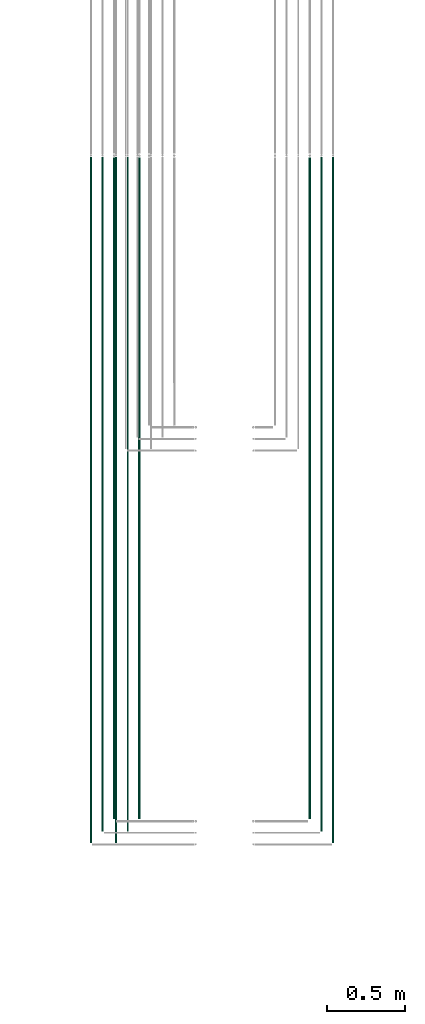
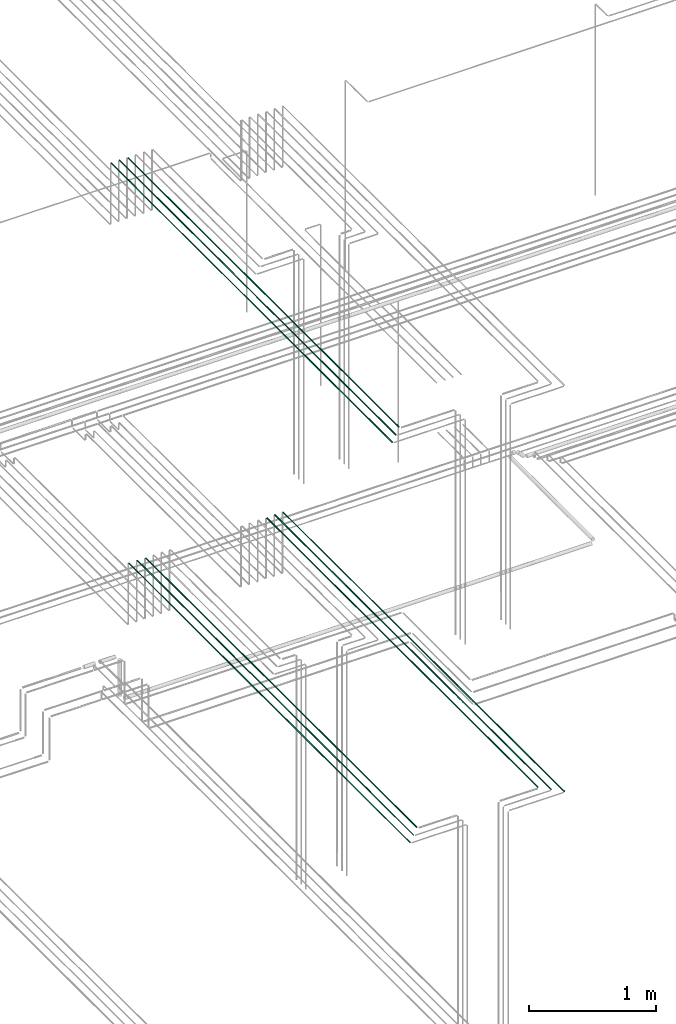
# One storey, part 10 of 331: 9 flow segments.
"""IFC2X3 building model written with IfcOpenShell, lengths in millimetres."""

from ifc_helpers import new_model, entity, si_unit, converted_unit, derived_unit, direction, frame, frame_2d, origin, origin_2d_with_axis, place, context, subcontext, project, spatial, circle, extrude, type_object, element, save


model = new_model("IFC2X3")

# Units and contexts
model_context = context("Model", 3, precision=0.01, world=origin(), true_north=direction((6.12303176911189e-17, 1.0)))
body_context = subcontext(model_context, "Body", "Model", "MODEL_VIEW")
ifc_project = project(units=[si_unit("LENGTHUNIT", "METRE", prefix="MILLI"), si_unit("AREAUNIT", "SQUARE_METRE"), si_unit("VOLUMEUNIT", "CUBIC_METRE"), converted_unit("PLANEANGLEUNIT", "DEGREE", entity("IfcRatioMeasure", 0.0174532925199433), si_unit("PLANEANGLEUNIT", "RADIAN"), dimensions=[0, 0, 0, 0, 0, 0, 0]), si_unit("MASSUNIT", "GRAM", prefix="KILO"), derived_unit("MASSDENSITYUNIT", [(si_unit("MASSUNIT", "GRAM", prefix="KILO"), 1), (si_unit("LENGTHUNIT", "METRE"), -3)]), derived_unit("MOMENTOFINERTIAUNIT", [(si_unit("LENGTHUNIT", "METRE"), 4)]), si_unit("TIMEUNIT", "SECOND"), si_unit("FREQUENCYUNIT", "HERTZ"), si_unit("THERMODYNAMICTEMPERATUREUNIT", "DEGREE_CELSIUS"), derived_unit("THERMALTRANSMITTANCEUNIT", [(si_unit("MASSUNIT", "GRAM", prefix="KILO"), 1), (si_unit("THERMODYNAMICTEMPERATUREUNIT", "KELVIN"), -1), (si_unit("TIMEUNIT", "SECOND"), -3)]), derived_unit("VOLUMETRICFLOWRATEUNIT", [(si_unit("LENGTHUNIT", "METRE"), 3), (si_unit("TIMEUNIT", "SECOND"), -1)]), derived_unit("MASSFLOWRATEUNIT", [(si_unit("MASSUNIT", "GRAM", prefix="KILO"), 1), (si_unit("TIMEUNIT", "SECOND"), -1)]), derived_unit("ROTATIONALFREQUENCYUNIT", [(si_unit("TIMEUNIT", "SECOND"), -1)]), si_unit("ELECTRICCURRENTUNIT", "AMPERE"), si_unit("ELECTRICVOLTAGEUNIT", "VOLT"), si_unit("POWERUNIT", "WATT"), si_unit("FORCEUNIT", "NEWTON", prefix="KILO"), si_unit("ILLUMINANCEUNIT", "LUX"), si_unit("LUMINOUSFLUXUNIT", "LUMEN"), si_unit("LUMINOUSINTENSITYUNIT", "CANDELA"), derived_unit("USERDEFINED", [(si_unit("MASSUNIT", "GRAM", prefix="KILO"), -1), (si_unit("LENGTHUNIT", "METRE"), -2), (si_unit("TIMEUNIT", "SECOND"), 3), (si_unit("LUMINOUSFLUXUNIT", "LUMEN"), 1)]), derived_unit("LINEARVELOCITYUNIT", [(si_unit("LENGTHUNIT", "METRE"), 1), (si_unit("TIMEUNIT", "SECOND"), -1)]), si_unit("PRESSUREUNIT", "PASCAL"), derived_unit("USERDEFINED", [(si_unit("LENGTHUNIT", "METRE"), -2), (si_unit("MASSUNIT", "GRAM", prefix="KILO"), 1), (si_unit("TIMEUNIT", "SECOND"), -2)]), derived_unit("LINEARFORCEUNIT", [(si_unit("MASSUNIT", "GRAM", prefix="KILO"), 1), (si_unit("LENGTHUNIT", "METRE"), 1), (si_unit("TIMEUNIT", "SECOND"), -2), (si_unit("LENGTHUNIT", "METRE"), -1)]), derived_unit("PLANARFORCEUNIT", [(si_unit("MASSUNIT", "GRAM", prefix="KILO"), 1), (si_unit("LENGTHUNIT", "METRE"), 1), (si_unit("TIMEUNIT", "SECOND"), -2), (si_unit("LENGTHUNIT", "METRE"), -2)])], contexts=[model_context])

# Site, building, storey
site_placement = place(None, frame((0.0, -0.00077364408347762, 0.0)))
site = spatial("IfcSite", under=ifc_project, at=site_placement, CompositionType="ELEMENT")
building_placement = place(site_placement, origin())
building = spatial("IfcBuilding", under=site, at=building_placement, CompositionType="ELEMENT")
storey_placement = place(building_placement, origin())
storey = spatial("IfcBuildingStorey", under=building, at=storey_placement, CompositionType="ELEMENT", Elevation=0.0)

# Flow segments
pipe_segment_type = type_object("IfcPipeSegmentType", PredefinedType="NOTDEFINED")
flow_segment_1_placement = place(storey_placement, frame((26313.5132663482, 1365.48876707896, 15142.4047277641)))
element("IfcFlowSegment", 1, at=flow_segment_1_placement, inside=storey, type_object=pipe_segment_type, context=body_context, shape_type="SweptSolid", body=[
    extrude(circle(Radius=6.0, at=frame_2d((0.0, 2.16573425859679e-12), x_axis=(1.0, 0.0))), frame((7.59527223591454, 0.0, 7.59527223591887), z_axis=(0.0, 1.0, 0.0), x_axis=(1.0, 0.0, 0.0)), (0.0, 0.0, 1.0), 4264.13179674845),
])
flow_segment_2_placement = place(storey_placement, frame((26390.5132663482, 1286.48876707975, 15144.4047277641)))
element("IfcFlowSegment", 2, at=flow_segment_2_placement, inside=storey, type_object=pipe_segment_type, context=body_context, shape_type="SweptSolid", body=[
    extrude(circle(Radius=4.0, at=origin_2d_with_axis()), frame((5.59527223591499, 0.0, 5.59527223591499), z_axis=(0.0, 1.0, 0.0), x_axis=(1.0, 0.0, 0.0)), (0.0, 0.0, 1.0), 4347.13179674766),
])
flow_segment_3_placement = place(storey_placement, frame((26465.5132663482, 1211.48876707917, 15144.4047277641)))
element("IfcFlowSegment", 3, at=flow_segment_3_placement, inside=storey, type_object=pipe_segment_type, context=body_context, shape_type="SweptSolid", body=[
    extrude(circle(Radius=4.0, at=origin_2d_with_axis()), frame((5.59527223591499, 0.0, 5.59527223591499), z_axis=(0.0, 1.0, 0.0), x_axis=(1.0, 0.0, 0.0)), (0.0, 0.0, 1.0), 4422.13179674824),
])
flow_segment_4_placement = place(storey_placement, frame((25213.5132663482, 1365.48876707899, 15142.4047277641)))
element("IfcFlowSegment", 4, at=flow_segment_4_placement, inside=storey, type_object=pipe_segment_type, context=body_context, shape_type="SweptSolid", body=[
    extrude(circle(Radius=6.0, at=frame_2d((0.0, 2.16573425859679e-12), x_axis=(1.0, 0.0))), frame((7.59527223591454, 0.0, 7.59527223591887), z_axis=(0.0, 1.0, 0.0), x_axis=(1.0, 0.0, 0.0)), (0.0, 0.0, 1.0), 4264.13179674841),
])
flow_segment_5_placement = place(storey_placement, frame((25140.5132663482, 1286.48876707975, 15144.4047277641)))
element("IfcFlowSegment", 5, at=flow_segment_5_placement, inside=storey, type_object=pipe_segment_type, context=body_context, shape_type="SweptSolid", body=[
    extrude(circle(Radius=4.0, at=origin_2d_with_axis()), frame((5.59527223591499, 0.0, 5.59527223591499), z_axis=(0.0, 1.0, 0.0), x_axis=(1.0, 0.0, 0.0)), (0.0, 0.0, 1.0), 4347.13179674766),
])
flow_segment_6_placement = place(storey_placement, frame((25065.5132663482, 1211.4887670792, 15144.4047277641)))
element("IfcFlowSegment", 6, at=flow_segment_6_placement, inside=storey, type_object=pipe_segment_type, context=body_context, shape_type="SweptSolid", body=[
    extrude(circle(Radius=4.0, at=origin_2d_with_axis()), frame((5.59527223591499, 0.0, 5.59527223591499), z_axis=(0.0, 1.0, 0.0), x_axis=(1.0, 0.0, 0.0)), (0.0, 0.0, 1.0), 4422.1317967482),
])
flow_segment_7_placement = place(storey_placement, frame((25051.7436346567, 1365.48876707974, 19042.4047277641)))
element("IfcFlowSegment", 7, at=flow_segment_7_placement, inside=storey, type_object=pipe_segment_type, context=body_context, shape_type="SweptSolid", body=[
    extrude(circle(Radius=6.0, at=origin_2d_with_axis()), frame((7.59527223591887, 0.0, 7.5952722359167), z_axis=(0.0, 1.0, 0.0), x_axis=(1.0, 0.0, 0.0)), (0.0, 0.0, 1.0), 4264.13179674761),
])
flow_segment_8_placement = place(storey_placement, frame((24978.7436346567, 1286.48876707973, 19044.4047277641)))
element("IfcFlowSegment", 8, at=flow_segment_8_placement, inside=storey, type_object=pipe_segment_type, context=body_context, shape_type="SweptSolid", body=[
    extrude(circle(Radius=4.0, at=origin_2d_with_axis()), frame((5.59527223591932, 0.0, 5.59527223591499), z_axis=(0.0, 1.0, 0.0), x_axis=(1.0, 0.0, 0.0)), (0.0, 0.0, 1.0), 4347.13179674762),
])
flow_segment_9_placement = place(storey_placement, frame((24903.7436346567, 1211.48876707969, 19044.4047277641)))
element("IfcFlowSegment", 9, at=flow_segment_9_placement, inside=storey, type_object=pipe_segment_type, context=body_context, shape_type="SweptSolid", body=[
    extrude(circle(Radius=4.0, at=origin_2d_with_axis()), frame((5.59527223591499, 0.0, 5.59527223591499), z_axis=(0.0, 1.0, 0.0), x_axis=(1.0, 0.0, 0.0)), (0.0, 0.0, 1.0), 4422.13179674766),
])

save(model, "model.ifc")
